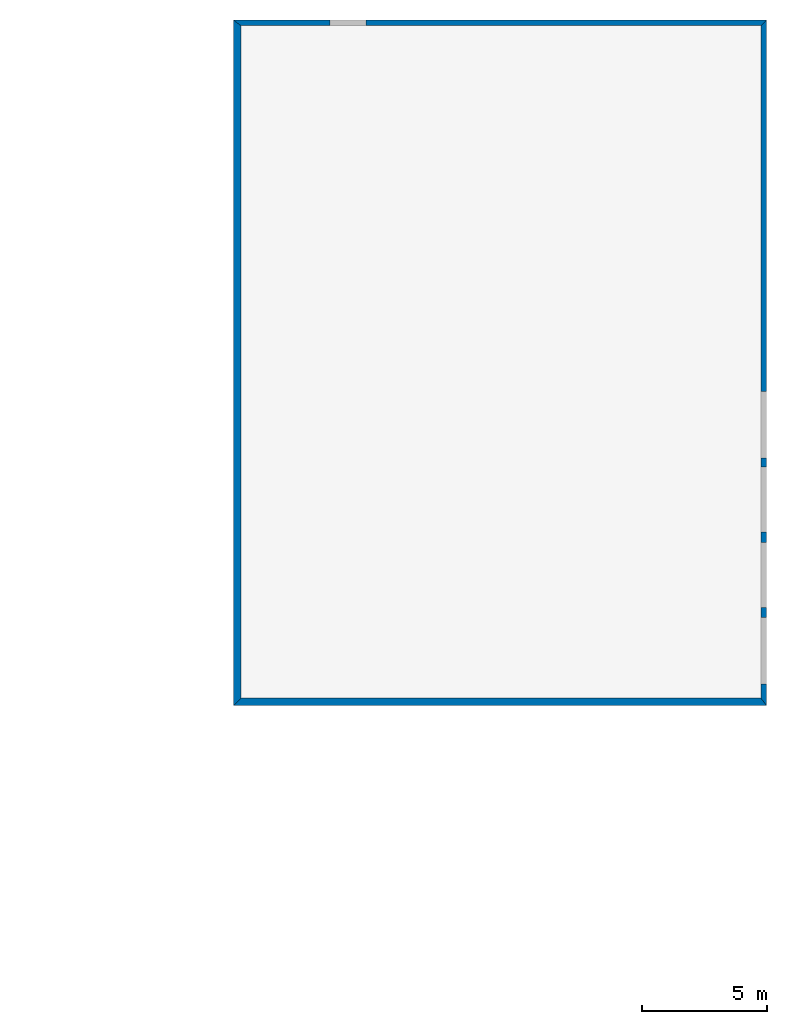
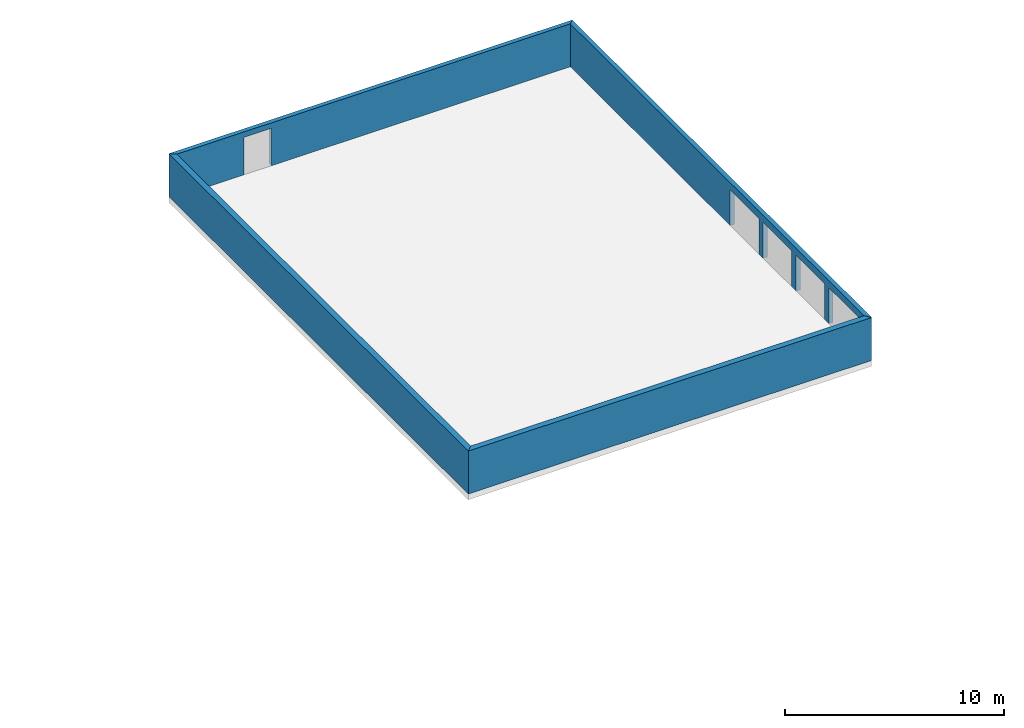
# One storey, part 7 of 72: 4 walls, 5 openings.
"""IFC2X3 building model written with IfcOpenShell, lengths in metres."""

from ifc_helpers import new_model, entity, si_unit, converted_unit, derived_unit, frame, origin_with_axes, place, context, project, spatial, polyline, outline, extrude, material, layer, layer_set, layer_usage, element, save


model = new_model("IFC2X3")

# Units and contexts
context_of_model_1 = context(None, 3, world=origin_with_axes())
context_of_model_2 = context(None, 3, world=origin_with_axes())
context_of_model_3 = context(None, 2, world=origin_with_axes())
context_of_model_4 = context(None, 3, world=origin_with_axes())
ifc_project = project(units=[si_unit("LENGTHUNIT", "METRE"), si_unit("AREAUNIT", "SQUARE_METRE"), si_unit("ELECTRICCURRENTUNIT", "AMPERE"), si_unit("ELECTRICVOLTAGEUNIT", "VOLT"), si_unit("ELECTRICRESISTANCEUNIT", "OHM"), si_unit("POWERUNIT", "WATT"), si_unit("MASSUNIT", "GRAM"), si_unit("SOLIDANGLEUNIT", "STERADIAN"), si_unit("THERMODYNAMICTEMPERATUREUNIT", "KELVIN"), si_unit("PRESSUREUNIT", "PASCAL"), si_unit("LUMINOUSFLUXUNIT", "LUMEN"), si_unit("ILLUMINANCEUNIT", "LUX"), si_unit("FREQUENCYUNIT", "HERTZ"), si_unit("VOLUMEUNIT", "CUBIC_METRE"), si_unit("TIMEUNIT", "SECOND"), derived_unit("VOLUMETRICFLOWRATEUNIT", [(si_unit("TIMEUNIT", "SECOND"), -1), (si_unit("VOLUMEUNIT", "CUBIC_METRE"), 1)]), derived_unit("THERMALTRANSMITTANCEUNIT", [(si_unit("AREAUNIT", "SQUARE_METRE"), -1), (si_unit("THERMODYNAMICTEMPERATUREUNIT", "KELVIN"), -1), (si_unit("POWERUNIT", "WATT"), 1)]), converted_unit("PLANEANGLEUNIT", "DEGREE", entity("IfcPlaneAngleMeasure", 57.29577951308232), si_unit("PLANEANGLEUNIT", "RADIAN"), dimensions=[0, 0, 0, 0, 0, 0, 0])], contexts=[context_of_model_1, context_of_model_2, context_of_model_3, context_of_model_4])

# Site, building, storey
site = spatial("IfcSite", under=ifc_project, CompositionType="ELEMENT")
building_placement = place(None, origin_with_axes())
building = spatial("IfcBuilding", under=site, at=building_placement, Name="200", CompositionType="ELEMENT")
storey_placement = place(building_placement, frame((0.0, 0.0, 15.68000030517578), z_axis=(0.0, 0.0, 1.0), x_axis=(1.0, 0.0, 0.0)))
storey = spatial("IfcBuildingStorey", under=building, at=storey_placement, Name="3.etasje", CompositionType="ELEMENT", Elevation=15.68000030517578)

# Wall
ifc_material_1 = material(Name="Layer-YV1 20.0cm")
ifc_layer_1 = layer(ifc_material_1, 0.2999992370605469, ventilated=False)
ifc_layer_set_1 = layer_set([ifc_layer_1])
ifc_layer_usage_1 = layer_usage(ifc_layer_set_1, "AXIS2", "POSITIVE", 0.0)
wall_1_placement = place(storey_placement, frame((27.65441703796387, 62.69001007080078, 0.0), z_axis=(0.0, 0.0, 1.0), x_axis=(1.0, 0.0, 0.0)))
element("IfcWallStandardCase", 1, at=wall_1_placement, inside=storey, material=ifc_layer_usage_1, Name="YV1 20.0cm", context=context_of_model_1, shape_type="SweptSolid", body=[
    extrude(outline(polyline([(0.0, 0.0), (21.29314231872559, 0.0), (21.06314659118652, 0.2999992370605469), (0.2999992370605469, 0.2999992370605469), (0.0, 0.0)])), origin_with_axes(), (0.0, 0.0, 1.0), 2.4),
])

# Wall, openings
ifc_material_2 = material(Name="Layer-YV1 20.0cm")
ifc_layer_2 = layer(ifc_material_2, 0.2299957275390625, ventilated=False)
ifc_layer_set_2 = layer_set([ifc_layer_2])
ifc_layer_usage_2 = layer_usage(ifc_layer_set_2, "AXIS2", "POSITIVE", 0.0)
wall_2_placement = place(storey_placement, frame((48.94755935668945, 62.69001007080078, 0.0), z_axis=(0.0, 0.0, 1.0), x_axis=(-4.371138828673793e-08, 1.0, 0.0)))
wall_2 = element("IfcWallStandardCase", 2, at=wall_2_placement, inside=storey, material=ifc_layer_usage_2, Name="YV1 20.0cm", context=context_of_model_1, shape_type="SweptSolid", body=[
    extrude(outline(polyline([(0.0, 0.0), (27.3760452270508, -2.117582368135751e-22), (27.15060424804689, 0.2299957275390638), (0.2999992370605479, 0.2299957275390606), (0.0, 0.0)])), frame((0.0, 0.0, 0.0), z_axis=(0.0, 0.0, 1.0), x_axis=(0.999999999999999, -4.371139018529452e-08, 0.0)), (0.0, 0.0, 1.0), 2.4),
])
opening_1_placement = place(wall_2_placement, frame((0.8667755227487461, 0.2299956896510977, 0.0), z_axis=(0.0, 0.0, 1.0), x_axis=(1.0, 0.0, 0.0)))
element("IfcOpeningElement", 3, at=opening_1_placement, cuts=wall_2, context=context_of_model_1, shape_type="SweptSolid", body=[
    extrude(outline(polyline([(0.0, 0.0), (2.0, 0.0), (2.0, 2.647000000000001), (0.0, 2.647000000000001), (0.0, 0.0)])), frame((0.0, 0.0, 0.0), z_axis=(4.371138920746386e-08, 0.999999999999999, 0.0), x_axis=(0.0, 0.0, 1.0)), (0.0, 4.371138920746387e-08, -0.9999999999999992), 0.2299957275390625),
])
opening_2_placement = place(wall_2_placement, frame((3.919479380170614, 0.2299955562131686, 0.0), z_axis=(0.0, 0.0, 1.0), x_axis=(1.0, 0.0, 0.0)))
element("IfcOpeningElement", 4, at=opening_2_placement, cuts=wall_2, context=context_of_model_1, shape_type="SweptSolid", body=[
    extrude(outline(polyline([(0.0, 0.0), (2.0, 0.0), (2.0, 2.592000000000001), (0.0, 2.592000000000001), (0.0, 0.0)])), frame((0.0, 0.0, 0.0), z_axis=(4.371139115961131e-08, 0.999999999999999, 0.0), x_axis=(0.0, 0.0, 1.0)), (0.0, 4.371139115961132e-08, -0.9999999999999992), 0.2299957275390625),
])
opening_3_placement = place(wall_2_placement, frame((6.93166352323702, 0.2299954245464093, 0.0), z_axis=(0.0, 0.0, 1.0), x_axis=(1.0, 0.0, 0.0)))
element("IfcOpeningElement", 5, at=opening_3_placement, cuts=wall_2, context=context_of_model_1, shape_type="SweptSolid", body=[
    extrude(outline(polyline([(0.0, 0.0), (2.0, 0.0), (2.0, 2.592000000000001), (0.0, 2.592000000000001), (0.0, 0.0)])), frame((0.0, 0.0, 0.0), z_axis=(4.371138841831989e-08, 0.999999999999999, 0.0), x_axis=(0.0, 0.0, 1.0)), (0.0, 4.37113884183199e-08, -0.9999999999999992), 0.2299957275390625),
])
opening_4_placement = place(wall_2_placement, frame((9.893600473920614, 0.22999529507603, 0.0), z_axis=(0.0, 0.0, 1.0), x_axis=(1.0, 0.0, 0.0)))
element("IfcOpeningElement", 6, at=opening_4_placement, cuts=wall_2, context=context_of_model_1, shape_type="SweptSolid", body=[
    extrude(outline(polyline([(0.0, 0.0), (2.0, 0.0), (2.0, 2.641999999999999), (0.0, 2.641999999999999), (0.0, 0.0)])), frame((0.0, 0.0, 0.0), z_axis=(4.371138962606529e-08, 0.999999999999999, 0.0), x_axis=(0.0, 0.0, 1.0)), (0.0, 4.371138962606529e-08, -0.9999999999999992), 0.2299957275390625),
])

# Wall, opening
ifc_material_3 = material(Name="Layer-YV1 20.0cm")
ifc_layer_3 = layer(ifc_material_3, 0.2254409790039063, ventilated=False)
ifc_layer_set_3 = layer_set([ifc_layer_3])
ifc_layer_usage_3 = layer_usage(ifc_layer_set_3, "AXIS2", "POSITIVE", 0.0)
wall_3_placement = place(storey_placement, frame((48.94755935668945, 90.06605529785156, 0.0), z_axis=(0.0, 0.0, 1.0), x_axis=(-1.0, -8.742277657347586e-08, 0.0)))
wall_3 = element("IfcWallStandardCase", 7, at=wall_3_placement, inside=storey, material=ifc_layer_usage_3, Name="YV1 20.0cm", context=context_of_model_1, shape_type="SweptSolid", body=[
    extrude(outline(polyline([(0.0, 0.0), (21.29314231872559, 0.0), (20.99314308166505, 0.2254409790038975), (0.2299957275390654, 0.2254409790039057), (0.0, 0.0)])), frame((0.0, 0.0, 0.0), z_axis=(0.0, 0.0, 1.0), x_axis=(0.9999999999999961, -8.742277990793024e-08, 0.0)), (0.0, 0.0, 1.0), 2.4),
])
opening_5_placement = place(wall_3_placement, frame((15.99285509173011, 0.2254395808640481, 0.0), z_axis=(0.0, 0.0, 1.0), x_axis=(1.0, 0.0, 0.0)))
element("IfcOpeningElement", 8, at=opening_5_placement, cuts=wall_3, context=context_of_model_1, shape_type="SweptSolid", body=[
    extrude(outline(polyline([(0.0, 0.0), (2.099999904632568, 0.0), (2.099999904632568, 1.450004577636714), (0.0, 1.450004577636714), (0.0, 0.0)])), frame((0.0, 0.0, 0.0), z_axis=(8.742277548710901e-08, 0.9999999999999962, 0.0), x_axis=(0.0, 0.0, 1.0)), (0.0, 8.742277548710901e-08, -0.9999999999999962), 0.2254409790039063),
])

# Wall
wall_4_placement = place(storey_placement, frame((27.65441703796387, 90.06605529785156, 0.0), z_axis=(0.0, 0.0, 1.0), x_axis=(-4.371138828673793e-08, -1.0, 0.0)))
element("IfcWallStandardCase", 9, at=wall_4_placement, inside=storey, material=ifc_layer_usage_1, Name="YV1 20.0cm", context=context_of_model_1, shape_type="SweptSolid", body=[
    extrude(outline(polyline([(0.0, 0.0), (27.37604522705078, 0.0), (27.07604598999023, 0.2999992370605485), (0.2254409790038971, 0.2999992370605482), (0.0, 0.0)])), frame((0.0, 0.0, 0.0), z_axis=(0.0, 0.0, 1.0), x_axis=(0.9999999999999991, 4.371139005552e-08, 0.0)), (0.0, 0.0, 1.0), 2.4),
])

save(model, "model.ifc")
